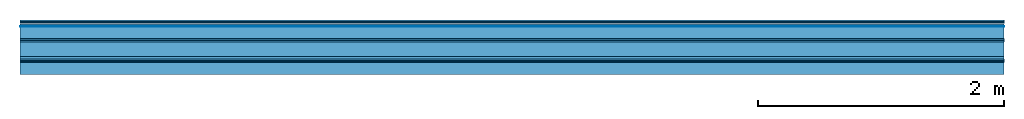
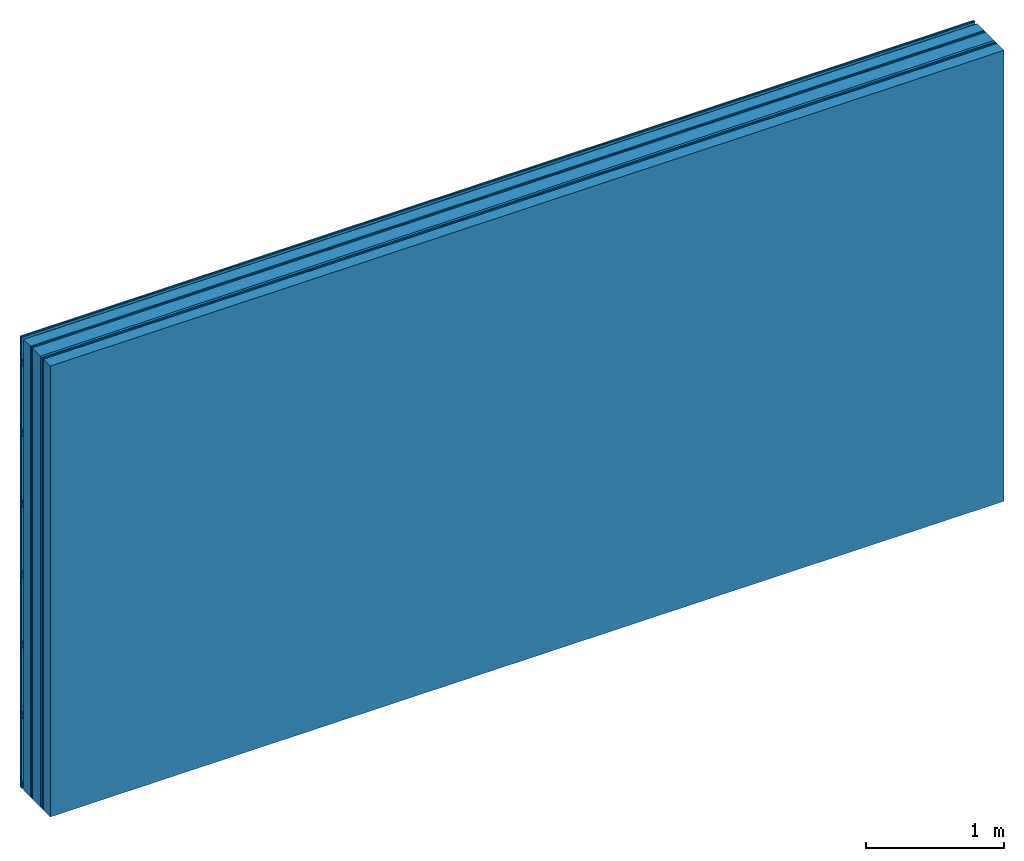
# One storey: 9 plates, 3 members, 1 element without a shape of its own.
"""IFC4 building model written with IfcOpenShell, lengths in metres."""

from ifc_helpers import new_model, si_unit, derived_unit, direction, frame, frame_2d, origin, origin_with_axes, place, context, project, spatial, polyline, rectangle, outline, extrude, material, layer, layer_set, type_object, element, aggregate, save


model = new_model("IFC4")

# Units and contexts
plan_context = context("Plan", 3, precision=1e-05, world=origin(), true_north=direction((0.0, 1.0)))
model_context = context("Model", 3, precision=1e-05, world=origin(), true_north=direction((0.0, 1.0)))
ifc_project = project(units=[si_unit("LENGTHUNIT", "METRE"), derived_unit("SOUNDPRESSUREUNIT", [(si_unit("PRESSUREUNIT", "PASCAL", prefix="MICRO"), 0)]), si_unit("ENERGYUNIT", "JOULE", prefix="MEGA"), si_unit("MASSUNIT", "GRAM", prefix="KILO"), derived_unit("THERMALTRANSMITTANCEUNIT", [(si_unit("POWERUNIT", "WATT"), 1), (si_unit("AREAUNIT", "SQUARE_METRE"), -1), (si_unit("THERMODYNAMICTEMPERATUREUNIT", "KELVIN"), -1)]), derived_unit("AREADENSITYUNIT", [(si_unit("MASSUNIT", "GRAM", prefix="KILO"), 1), (si_unit("AREAUNIT", "SQUARE_METRE"), -1)]), derived_unit("USERDEFINED", [(si_unit("ENERGYUNIT", "JOULE", prefix="MEGA"), 1), (si_unit("AREAUNIT", "SQUARE_METRE"), -1)])], contexts=[plan_context, model_context])

# Site, building, storey
site = spatial("IfcSite", under=ifc_project)
building_placement = place(None, origin())
building = spatial("IfcBuilding", under=site, at=building_placement)
storey_placement = place(building_placement, origin())
storey = spatial("IfcBuildingStorey", under=building, at=storey_placement)

# Wall, members, plates
ifc_material_1 = material(Name="joints", Category="04.017")
ifc_layer_1 = layer(ifc_material_1, 0.0, Name="Surface")
ifc_material_2 = material(Name="Rigidur H", Category="03.007")
ifc_layer_2 = layer(ifc_material_2, 0.0125, Name="Cover 2nd layer")
ifc_layer_3 = layer(ifc_material_2, 0.0125, Name="Cover 1st layer")
ifc_layer_4 = layer(None, 0.027, Name="Battens / profiles")
ifc_material_3 = material(Name="Air")
ifc_layer_5 = layer(ifc_material_3, 0.001, Name="Coupling")
ifc_material_4 = material(Name="of the art")
ifc_layer_6 = layer(ifc_material_4, 0.0, Name="Bond")
ifc_layer_7 = layer(None, 0.1, Name="Support")
ifc_layer_8 = layer(ifc_material_4, 0.0, Name="Bond")
ifc_layer_9 = layer(ifc_material_2, 0.0125, Name="outside 1st layer")
ifc_layer_10 = layer(ifc_material_2, 0.0125, Name="outside 2nd layer")
ifc_material_5 = material(Category="10.008")
ifc_layer_11 = layer(ifc_material_5, 0.12, Name="Intermediate insulation")
ifc_layer_12 = layer(ifc_material_3, 0.02, Name="Air gap")
ifc_layer_13 = layer(ifc_material_2, 0.0125, Name="2nd layer")
ifc_layer_14 = layer(ifc_material_2, 0.0125, Name="outside 1st layer")
ifc_layer_15 = layer(ifc_material_4, 0.0, Name="Bond")
ifc_layer_16 = layer(None, 0.1, Name="Support")
ifc_layer_17 = layer(ifc_material_4, 0.0, Name="Bond")
ifc_layer_set = layer_set([ifc_layer_1, ifc_layer_2, ifc_layer_3, ifc_layer_4, ifc_layer_5, ifc_layer_6, ifc_layer_7, ifc_layer_8, ifc_layer_9, ifc_layer_10, ifc_layer_11, ifc_layer_12, ifc_layer_13, ifc_layer_14, ifc_layer_15, ifc_layer_16, ifc_layer_17])
wall_type = type_object("IfcWallType", Name="B0326", PredefinedType="NOTDEFINED", material=ifc_layer_set)
wall_placement = place(None, frame((0.0, 0.0, 0.0), z_axis=(0.0, -1.0, 0.0), x_axis=(1.0, 0.0, 0.0)))
wall = element("IfcWall", 1, at=wall_placement, inside=storey, type_object=wall_type, material=ifc_layer_set, Name="Wall #1")
ifc_material_6 = material()
member_1_placement = place(wall_placement, origin())
member_1 = element("IfcMember", 2, at=member_1_placement, material=ifc_material_6, Name="Battens / profiles", context=plan_context, shape_type="SweptSolid", body=[
    extrude(outline(polyline([(0.0, 0.0), (0.06, 0.0), (0.04, 0.02), (0.02, 0.02), (0.0, 0.0)])), frame((0.0, 0.0, 0.032), z_axis=(1.0, 0.0, 0.0), x_axis=(0.0, 1.0, 0.0)), (0.0, 0.0, 1.0), 8.0),
    extrude(outline(polyline([(0.0, 0.0), (0.06, 0.0), (0.04, 0.02), (0.02, 0.02), (0.0, 0.0)])), frame((0.0, 0.625, 0.032), z_axis=(1.0, 0.0, 0.0), x_axis=(0.0, 1.0, 0.0)), (0.0, 0.0, 1.0), 8.0),
    extrude(outline(polyline([(0.0, 0.0), (0.06, 0.0), (0.04, 0.02), (0.02, 0.02), (0.0, 0.0)])), frame((0.0, 1.25, 0.032), z_axis=(1.0, 0.0, 0.0), x_axis=(0.0, 1.0, 0.0)), (0.0, 0.0, 1.0), 8.0),
    extrude(outline(polyline([(0.0, 0.0), (0.06, 0.0), (0.04, 0.02), (0.02, 0.02), (0.0, 0.0)])), frame((0.0, 1.875, 0.032), z_axis=(1.0, 0.0, 0.0), x_axis=(0.0, 1.0, 0.0)), (0.0, 0.0, 1.0), 8.0),
    extrude(outline(polyline([(0.0, 0.0), (0.06, 0.0), (0.04, 0.02), (0.02, 0.02), (0.0, 0.0)])), frame((0.0, 2.5, 0.032), z_axis=(1.0, 0.0, 0.0), x_axis=(0.0, 1.0, 0.0)), (0.0, 0.0, 1.0), 8.0),
    extrude(outline(polyline([(0.0, 0.0), (0.06, 0.0), (0.04, 0.02), (0.02, 0.02), (0.0, 0.0)])), frame((0.0, 3.125, 0.032), z_axis=(1.0, 0.0, 0.0), x_axis=(0.0, 1.0, 0.0)), (0.0, 0.0, 1.0), 8.0),
    extrude(outline(polyline([(0.0, 0.0), (0.06, 0.0), (0.04, 0.02), (0.02, 0.02), (0.0, 0.0)])), frame((0.0, 3.75, 0.032), z_axis=(1.0, 0.0, 0.0), x_axis=(0.0, 1.0, 0.0)), (0.0, 0.0, 1.0), 8.0),
])
ifc_material_7 = material(Name="OSB")
member_2_placement = place(wall_placement, origin())
member_2 = element("IfcMember", 3, at=member_2_placement, material=ifc_material_7, Name="Support", context=plan_context, shape_type="SweptSolid", body=[
    extrude(rectangle(XDim=1.0, YDim=0.1, at=frame_2d((0.5, 0.05), x_axis=(1.0, 0.0))), frame((0.0, 4.0, 0.053), z_axis=(0.0, -1.0, 0.0), x_axis=(1.0, 0.0, 0.0)), (0.0, 0.0, 1.0), 4.0),
    extrude(rectangle(XDim=1.0, YDim=0.1, at=frame_2d((0.5, 0.05), x_axis=(1.0, 0.0))), frame((1.0, 4.0, 0.053), z_axis=(0.0, -1.0, 0.0), x_axis=(1.0, 0.0, 0.0)), (0.0, 0.0, 1.0), 4.0),
    extrude(rectangle(XDim=1.0, YDim=0.1, at=frame_2d((0.5, 0.05), x_axis=(1.0, 0.0))), frame((2.0, 4.0, 0.053), z_axis=(0.0, -1.0, 0.0), x_axis=(1.0, 0.0, 0.0)), (0.0, 0.0, 1.0), 4.0),
    extrude(rectangle(XDim=1.0, YDim=0.1, at=frame_2d((0.5, 0.05), x_axis=(1.0, 0.0))), frame((3.0, 4.0, 0.053), z_axis=(0.0, -1.0, 0.0), x_axis=(1.0, 0.0, 0.0)), (0.0, 0.0, 1.0), 4.0),
    extrude(rectangle(XDim=1.0, YDim=0.1, at=frame_2d((0.5, 0.05), x_axis=(1.0, 0.0))), frame((4.0, 4.0, 0.053), z_axis=(0.0, -1.0, 0.0), x_axis=(1.0, 0.0, 0.0)), (0.0, 0.0, 1.0), 4.0),
    extrude(rectangle(XDim=1.0, YDim=0.1, at=frame_2d((0.5, 0.05), x_axis=(1.0, 0.0))), frame((5.0, 4.0, 0.053), z_axis=(0.0, -1.0, 0.0), x_axis=(1.0, 0.0, 0.0)), (0.0, 0.0, 1.0), 4.0),
    extrude(rectangle(XDim=1.0, YDim=0.1, at=frame_2d((0.5, 0.05), x_axis=(1.0, 0.0))), frame((6.0, 4.0, 0.053), z_axis=(0.0, -1.0, 0.0), x_axis=(1.0, 0.0, 0.0)), (0.0, 0.0, 1.0), 4.0),
    extrude(rectangle(XDim=1.0, YDim=0.1, at=frame_2d((0.5, 0.05), x_axis=(1.0, 0.0))), frame((7.0, 4.0, 0.053), z_axis=(0.0, -1.0, 0.0), x_axis=(1.0, 0.0, 0.0)), (0.0, 0.0, 1.0), 4.0),
])
member_3_placement = place(wall_placement, origin())
member_3 = element("IfcMember", 4, at=member_3_placement, material=ifc_material_7, Name="Support", context=plan_context, shape_type="SweptSolid", body=[
    extrude(rectangle(XDim=1.0, YDim=0.1, at=frame_2d((0.5, 0.05), x_axis=(1.0, 0.0))), frame((0.0, 4.0, 0.343), z_axis=(0.0, -1.0, 0.0), x_axis=(1.0, 0.0, 0.0)), (0.0, 0.0, 1.0), 4.0),
    extrude(rectangle(XDim=1.0, YDim=0.1, at=frame_2d((0.5, 0.05), x_axis=(1.0, 0.0))), frame((1.0, 4.0, 0.343), z_axis=(0.0, -1.0, 0.0), x_axis=(1.0, 0.0, 0.0)), (0.0, 0.0, 1.0), 4.0),
    extrude(rectangle(XDim=1.0, YDim=0.1, at=frame_2d((0.5, 0.05), x_axis=(1.0, 0.0))), frame((2.0, 4.0, 0.343), z_axis=(0.0, -1.0, 0.0), x_axis=(1.0, 0.0, 0.0)), (0.0, 0.0, 1.0), 4.0),
    extrude(rectangle(XDim=1.0, YDim=0.1, at=frame_2d((0.5, 0.05), x_axis=(1.0, 0.0))), frame((3.0, 4.0, 0.343), z_axis=(0.0, -1.0, 0.0), x_axis=(1.0, 0.0, 0.0)), (0.0, 0.0, 1.0), 4.0),
    extrude(rectangle(XDim=1.0, YDim=0.1, at=frame_2d((0.5, 0.05), x_axis=(1.0, 0.0))), frame((4.0, 4.0, 0.343), z_axis=(0.0, -1.0, 0.0), x_axis=(1.0, 0.0, 0.0)), (0.0, 0.0, 1.0), 4.0),
    extrude(rectangle(XDim=1.0, YDim=0.1, at=frame_2d((0.5, 0.05), x_axis=(1.0, 0.0))), frame((5.0, 4.0, 0.343), z_axis=(0.0, -1.0, 0.0), x_axis=(1.0, 0.0, 0.0)), (0.0, 0.0, 1.0), 4.0),
    extrude(rectangle(XDim=1.0, YDim=0.1, at=frame_2d((0.5, 0.05), x_axis=(1.0, 0.0))), frame((6.0, 4.0, 0.343), z_axis=(0.0, -1.0, 0.0), x_axis=(1.0, 0.0, 0.0)), (0.0, 0.0, 1.0), 4.0),
    extrude(rectangle(XDim=1.0, YDim=0.1, at=frame_2d((0.5, 0.05), x_axis=(1.0, 0.0))), frame((7.0, 4.0, 0.343), z_axis=(0.0, -1.0, 0.0), x_axis=(1.0, 0.0, 0.0)), (0.0, 0.0, 1.0), 4.0),
])
plate_1_placement = place(wall_placement, origin())
plate_1 = element("IfcPlate", 5, at=plate_1_placement, material=ifc_material_2, Name="Cover 2nd layer", context=plan_context, shape_type="SweptSolid", body=[
    extrude(rectangle(XDim=8.0, YDim=4.0, at=frame_2d((4.0, 2.0), x_axis=(1.0, 0.0))), origin_with_axes(), (0.0, 0.0, 1.0), 0.0125),
])
plate_2_placement = place(wall_placement, origin())
plate_2 = element("IfcPlate", 6, at=plate_2_placement, material=ifc_material_2, Name="Cover 1st layer", context=plan_context, shape_type="SweptSolid", body=[
    extrude(rectangle(XDim=8.0, YDim=4.0, at=frame_2d((4.0, 2.0), x_axis=(1.0, 0.0))), frame((0.0, 0.0, 0.0125), z_axis=(0.0, 0.0, 1.0), x_axis=(1.0, 0.0, 0.0)), (0.0, 0.0, 1.0), 0.0125),
])
plate_3_placement = place(wall_placement, origin())
plate_3 = element("IfcPlate", 7, at=plate_3_placement, material=ifc_material_3, Name="Coupling", context=plan_context, shape_type="SweptSolid", body=[
    extrude(rectangle(XDim=8.0, YDim=4.0, at=frame_2d((4.0, 2.0), x_axis=(1.0, 0.0))), frame((0.0, 0.0, 0.052), z_axis=(0.0, 0.0, 1.0), x_axis=(1.0, 0.0, 0.0)), (0.0, 0.0, 1.0), 0.001),
])
plate_4_placement = place(wall_placement, origin())
plate_4 = element("IfcPlate", 8, at=plate_4_placement, material=ifc_material_2, Name="outside 1st layer", context=plan_context, shape_type="SweptSolid", body=[
    extrude(rectangle(XDim=8.0, YDim=4.0, at=frame_2d((4.0, 2.0), x_axis=(1.0, 0.0))), frame((0.0, 0.0, 0.153), z_axis=(0.0, 0.0, 1.0), x_axis=(1.0, 0.0, 0.0)), (0.0, 0.0, 1.0), 0.0125),
])
plate_5_placement = place(wall_placement, origin())
plate_5 = element("IfcPlate", 9, at=plate_5_placement, material=ifc_material_2, Name="outside 2nd layer", context=plan_context, shape_type="SweptSolid", body=[
    extrude(rectangle(XDim=8.0, YDim=4.0, at=frame_2d((4.0, 2.0), x_axis=(1.0, 0.0))), frame((0.0, 0.0, 0.1655), z_axis=(0.0, 0.0, 1.0), x_axis=(1.0, 0.0, 0.0)), (0.0, 0.0, 1.0), 0.0125),
])
plate_6_placement = place(wall_placement, origin())
plate_6 = element("IfcPlate", 10, at=plate_6_placement, material=ifc_material_5, Name="Intermediate insulation", context=plan_context, shape_type="SweptSolid", body=[
    extrude(rectangle(XDim=8.0, YDim=4.0, at=frame_2d((4.0, 2.0), x_axis=(1.0, 0.0))), frame((0.0, 0.0, 0.178), z_axis=(0.0, 0.0, 1.0), x_axis=(1.0, 0.0, 0.0)), (0.0, 0.0, 1.0), 0.12),
])
plate_7_placement = place(wall_placement, origin())
plate_7 = element("IfcPlate", 11, at=plate_7_placement, material=ifc_material_3, Name="Air gap", context=plan_context, shape_type="SweptSolid", body=[
    extrude(rectangle(XDim=8.0, YDim=4.0, at=frame_2d((4.0, 2.0), x_axis=(1.0, 0.0))), frame((0.0, 0.0, 0.298), z_axis=(0.0, 0.0, 1.0), x_axis=(1.0, 0.0, 0.0)), (0.0, 0.0, 1.0), 0.02),
])
plate_8_placement = place(wall_placement, origin())
plate_8 = element("IfcPlate", 12, at=plate_8_placement, material=ifc_material_2, Name="2nd layer", context=plan_context, shape_type="SweptSolid", body=[
    extrude(rectangle(XDim=8.0, YDim=4.0, at=frame_2d((4.0, 2.0), x_axis=(1.0, 0.0))), frame((0.0, 0.0, 0.318), z_axis=(0.0, 0.0, 1.0), x_axis=(1.0, 0.0, 0.0)), (0.0, 0.0, 1.0), 0.0125),
])
plate_9_placement = place(wall_placement, origin())
plate_9 = element("IfcPlate", 13, at=plate_9_placement, material=ifc_material_2, Name="outside 1st layer", context=plan_context, shape_type="SweptSolid", body=[
    extrude(rectangle(XDim=8.0, YDim=4.0, at=frame_2d((4.0, 2.0), x_axis=(1.0, 0.0))), frame((0.0, 0.0, 0.3305), z_axis=(0.0, 0.0, 1.0), x_axis=(1.0, 0.0, 0.0)), (0.0, 0.0, 1.0), 0.0125),
])
aggregate(wall, [plate_1, plate_2, member_1, plate_3, member_2, plate_4, plate_5, plate_6, plate_7, plate_8, plate_9, member_3])

save(model, "model.ifc")
